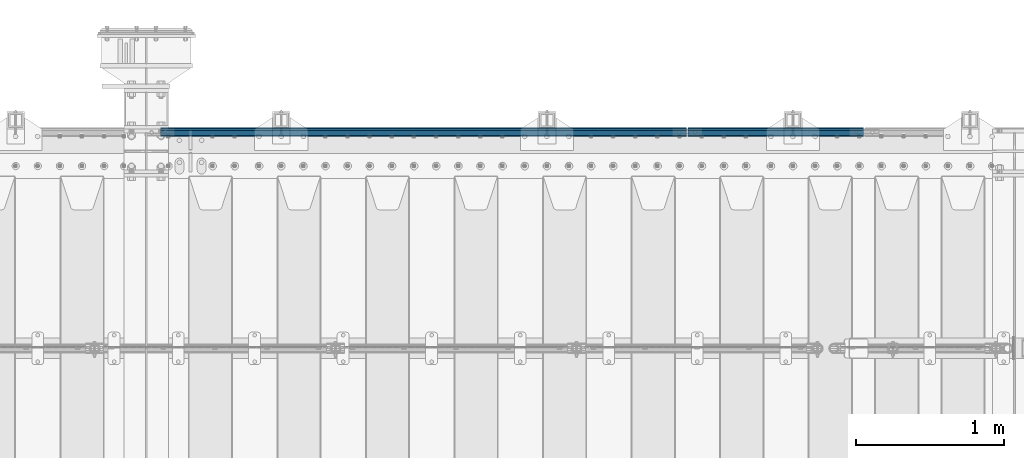
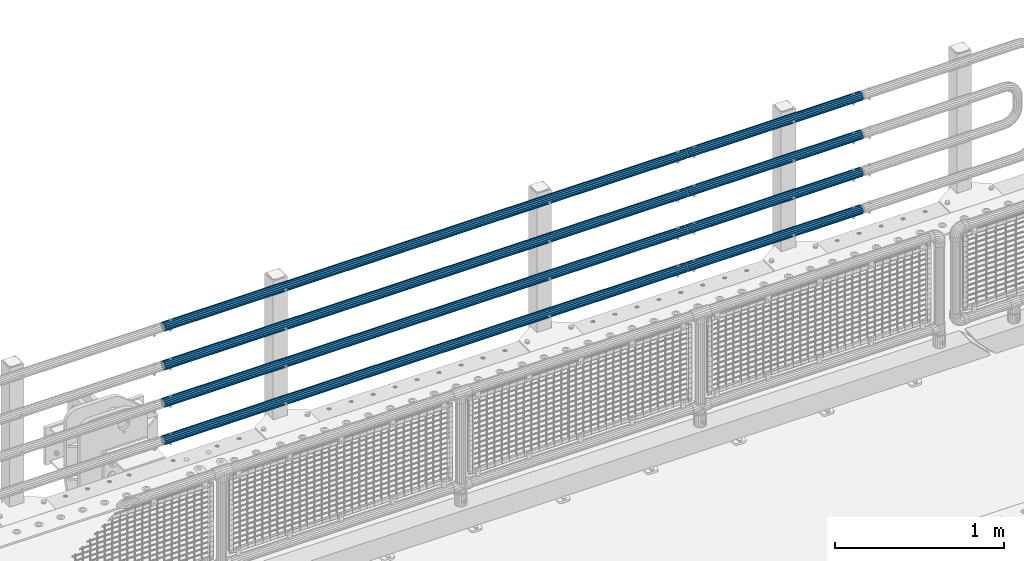
# One storey, part 135 of 242: 8 beams.
"""IFC2X3 building model written with IfcOpenShell, lengths in millimetres."""

import ifcopenshell
import ifcopenshell.guid

model = None  # the IFC model being written
_history = None  # IfcOwnerHistory: only IFC2X3 demands one
_inside = {}  # id of a spatial element -> (the spatial element, [elements in it])
_under = {}  # id of a project, library or spatial element -> (it, [spatial elements below it])
_declared = {}  # id of a project -> (the project, [libraries it declares])
_typed = {}  # id of a type object -> (the type object, [elements of that type])
_made_of = {}  # id of a material, layer set ... -> (it, [elements and type objects made of it])


def new_model(schema):
    """Start an empty IFC model of exactly this schema.

    Asked for "IFC4X3", IfcOpenShell would pick the latest addendum, in which some entities
    have other attributes; the version numbers below select the first issue.
    IFC2X3 requires an IfcOwnerHistory on every rooted entity: one is made here for all.
    """
    global model, _history
    if schema == "IFC4X3":
        model = ifcopenshell.file(schema_version=(4, 3, 0, 0))
    else:
        model = ifcopenshell.file(schema=schema)
    _inside.clear()
    _under.clear()
    _declared.clear()
    _typed.clear()
    _made_of.clear()
    _history = None
    if model.schema == "IFC2X3":
        org = make("IfcOrganization", Name="unknown")
        user = make(
            "IfcPersonAndOrganization",
            ThePerson=make("IfcPerson", FamilyName="unknown"),
            TheOrganization=org,
        )
        app = make(
            "IfcApplication",
            ApplicationDeveloper=org,
            Version="unknown",
            ApplicationFullName="unknown",
            ApplicationIdentifier="unknown",
        )
        _history = make(
            "IfcOwnerHistory",
            OwningUser=user,
            OwningApplication=app,
            ChangeAction="ADDED",
            CreationDate=0,
        )
    return model


def make(cls, **values):
    """One entity of the class cls with the attributes given. An attribute that is None is left unset."""
    return model.create_entity(
        cls, **{name: value for name, value in values.items() if value is not None}
    )


def rooted(cls, **values):
    """An entity with a GlobalId (a new one), such as an element, a storey or a relation."""
    return make(cls, GlobalId=ifcopenshell.guid.new(), OwnerHistory=_history, **values)


def si_unit(unit_type, name, prefix=None):
    """IfcSIUnit, for example si_unit("LENGTHUNIT", "METRE", prefix="MILLI")."""
    return make("IfcSIUnit", UnitType=unit_type, Prefix=prefix, Name=name)


def assignment(units):
    """IfcUnitAssignment: the units of a project."""
    return None if units is None else make("IfcUnitAssignment", Units=units)


def point(xyz):
    """IfcCartesianPoint."""
    return None if xyz is None else make("IfcCartesianPoint", Coordinates=xyz)


def direction(xyz):
    """IfcDirection."""
    return None if xyz is None else make("IfcDirection", DirectionRatios=xyz)


def frame(location, z_axis=None, x_axis=None):
    """IfcAxis2Placement3D, a coordinate frame: its origin and axes. An axis left out is left unset."""
    return make(
        "IfcAxis2Placement3D",
        Location=point(location),
        Axis=direction(z_axis),
        RefDirection=direction(x_axis),
    )


def origin_with_axes():
    """The frame at (0, 0, 0) with the z axis (0, 0, 1) and the x axis (1, 0, 0) written out."""
    return frame((0.0, 0.0, 0.0), z_axis=(0.0, 0.0, 1.0), x_axis=(1.0, 0.0, 0.0))


def place(relative_to, where):
    """IfcLocalPlacement: puts the frame where relative to a parent placement (None: the world)."""
    return make(
        "IfcLocalPlacement", PlacementRelTo=relative_to, RelativePlacement=where
    )


def context(
    kind, dimensions, precision=None, world=None, true_north=None, identifier=None
):
    """IfcGeometricRepresentationContext, for example the 3D "Model" context."""
    return make(
        "IfcGeometricRepresentationContext",
        ContextIdentifier=identifier,
        ContextType=kind,
        CoordinateSpaceDimension=dimensions,
        Precision=precision,
        WorldCoordinateSystem=world,
        TrueNorth=true_north,
    )


def subcontext(parent, identifier, kind, view, scale=None):
    """IfcGeometricRepresentationSubContext, for example "Body" below "Model"."""
    return make(
        "IfcGeometricRepresentationSubContext",
        ContextIdentifier=identifier,
        ContextType=kind,
        ParentContext=parent,
        TargetScale=scale,
        TargetView=view,
    )


def project(units=None, contexts=None):
    """IfcProject with its units and contexts."""
    return rooted(
        "IfcProject",
        Name="project",
        RepresentationContexts=contexts,
        UnitsInContext=assignment(units),
    )


def spatial(cls, under=None, at=None, **own):
    """A site, building, storey or space (cls), placed at a placement, below another one or the project."""
    s = rooted(cls, ObjectPlacement=at, **own)
    if under is not None:
        _under.setdefault(under.id(), (under, []))[1].append(s)
    return s


def faces_of(points, faces, orient=None, outer=None):
    """IfcFace entities. A face is a list of loops; a loop is a list of indices into points, from 0.

    orient and outer hold one flag for each loop. By default every Orientation is true, the
    first loop of a face is its IfcFaceOuterBound and the others are IfcFaceBound.
    """
    made = []
    for i, loops in enumerate(faces):
        bounds = []
        for j, loop in enumerate(loops):
            is_outer = j == 0 if outer is None else outer[i][j]
            bounds.append(
                make(
                    "IfcFaceOuterBound" if is_outer else "IfcFaceBound",
                    Bound=make("IfcPolyLoop", Polygon=[points[k] for k in loop]),
                    Orientation=True if orient is None else orient[i][j],
                )
            )
        made.append(make("IfcFace", Bounds=bounds))
    return made


def faceted_brep(points, faces, orient=None, outer=None, voids=None):
    """IfcFacetedBrep: a solid bounded by flat faces; with voids (closed shells), ...WithVoids."""
    shared = [point(p) for p in points]
    hull = make("IfcClosedShell", CfsFaces=faces_of(shared, faces, orient, outer))
    if voids is None:
        return make("IfcFacetedBrep", Outer=hull)
    return make(
        "IfcFacetedBrepWithVoids",
        Outer=hull,
        Voids=[
            make(cls, CfsFaces=faces_of(shared, fs, o, b)) for cls, fs, o, b in voids
        ],
    )


def shape(context_of_items, identifier, shape_type, items):
    """IfcShapeRepresentation: the items that make up one representation, for example the "Body"."""
    return make(
        "IfcShapeRepresentation",
        ContextOfItems=context_of_items,
        RepresentationIdentifier=identifier,
        RepresentationType=shape_type,
        Items=items,
    )


def material(Name=None, Category=None):
    """IfcMaterial."""
    return make("IfcMaterial", Name=Name, Category=Category)


def made_of(thing, what):
    """Note that an element or type object is made of a material, layer set ...; save() writes the relation."""
    if what is not None:
        _made_of.setdefault(what.id(), (what, []))[1].append(thing)
    return thing


def type_object(cls, material=None, **own):
    """A type object (cls), such as IfcWallType, which elements share."""
    return made_of(rooted(cls, **own), material)


def element(
    cls,
    number,
    at=None,
    inside=None,
    cuts=None,
    type_object=None,
    material=None,
    context=None,
    identifier="Body",
    shape_type=None,
    held_by="IfcProductDefinitionShape",
    body=None,
    shapes=None,
    **own,
):
    """One element of the class cls, such as IfcWall. Its Tag is "e" and its number.

    at: its placement. inside: the storey or other place that contains it. cuts: it is an
    opening in that element (IfcRelVoidsElement). A single representation is given by context,
    identifier, shape_type and body (its items); several are given by shapes. held_by: the class
    of the entity that holds the representations. save() writes the other relations.
    """
    e = rooted(cls, Tag="e%d" % number, ObjectPlacement=at, **own)
    if body is not None:
        shapes = [shape(context, identifier, shape_type, body)]
    if shapes is not None:
        e.Representation = make(held_by, Representations=shapes)
    if inside is not None:
        _inside.setdefault(inside.id(), (inside, []))[1].append(e)
    if cuts is not None:
        rooted(
            "IfcRelVoidsElement", RelatingBuildingElement=cuts, RelatedOpeningElement=e
        )
    if type_object is not None:
        _typed.setdefault(type_object.id(), (type_object, []))[1].append(e)
    return made_of(e, material)


def aggregate(whole, parts):
    """IfcRelAggregates: a whole, such as a stair, and the parts it consists of."""
    return rooted("IfcRelAggregates", RelatingObject=whole, RelatedObjects=parts)


def save(model, path):
    """Write the relations noted so far, then the file.

    IfcRelAggregates (storeys below a building ...), IfcRelContainedInSpatialStructure (elements
    in a storey), IfcRelDefinesByType, IfcRelAssociatesMaterial and IfcRelDeclares: one each for
    every whole, place, type object, material and project.
    """
    for whole, parts in _under.values():
        aggregate(whole, parts)
    for where, things in _inside.values():
        rooted(
            "IfcRelContainedInSpatialStructure",
            RelatedElements=things,
            RelatingStructure=where,
        )
    for kind, things in _typed.values():
        rooted("IfcRelDefinesByType", RelatedObjects=things, RelatingType=kind)
    for what, things in _made_of.values():
        rooted("IfcRelAssociatesMaterial", RelatedObjects=things, RelatingMaterial=what)
    for by, libraries in _declared.values():
        rooted("IfcRelDeclares", RelatingContext=by, RelatedDefinitions=libraries)
    model.write(path)


model = new_model("IFC2X3")

# Units and contexts
model_context = context("Model", 3, precision=1e-05, world=origin_with_axes())
body_context = subcontext(model_context, "Body", "Model", "MODEL_VIEW")
ifc_project = project(units=[si_unit("LENGTHUNIT", "METRE", prefix="MILLI"), si_unit("AREAUNIT", "SQUARE_METRE"), si_unit("VOLUMEUNIT", "CUBIC_METRE"), si_unit("MASSUNIT", "GRAM", prefix="KILO"), si_unit("TIMEUNIT", "SECOND"), si_unit("PLANEANGLEUNIT", "RADIAN"), si_unit("SOLIDANGLEUNIT", "STERADIAN"), si_unit("THERMODYNAMICTEMPERATUREUNIT", "DEGREE_CELSIUS"), si_unit("LUMINOUSINTENSITYUNIT", "LUMEN")], contexts=[model_context])

# Site, building, storey
site_placement = place(None, origin_with_axes())
site = spatial("IfcSite", under=ifc_project, at=site_placement, CompositionType="ELEMENT")
building_placement = place(site_placement, origin_with_axes())
building = spatial("IfcBuilding", under=site, at=building_placement, Name="Standard", CompositionType="ELEMENT")
storey_placement = place(building_placement, origin_with_axes())
storey = spatial("IfcBuildingStorey", under=building, at=storey_placement, Name="Undefined", CompositionType="ELEMENT", Elevation=0.0)

# Beams
ifc_material = material()
beam_type = type_object("IfcBeamType", PredefinedType="NOTDEFINED")
beam_1_placement = place(storey_placement, frame((-24755.0000000001, -17870.1499999998, 149.849999999726), z_axis=(0.0, 0.0, -1.0), x_axis=(-1.0, 0.0, 0.0)))
element("IfcBeam", 1, at=beam_1_placement, inside=storey, type_object=beam_type, material=ifc_material, context=body_context, shape_type="Brep", body=[
    faceted_brep([(0.0, -26.5499999999993, 0.0), (0.0, -24.5290015881765, 10.1602451292931), (3563.0, -24.5290015881765, 10.1602451292931), (3563.0, -26.5499999999993, 0.0), (0.0, -18.7736850405017, 18.7736850405028), (3563.0, -18.7736850405017, 18.7736850405028), (0.0, -10.1602451292929, 24.5290015881747), (3563.0, -10.1602451292929, 24.5290015881747), (0.0, 0.0, 26.55), (3563.0, 0.0, 26.55), (0.0, 10.1602451292929, 24.5290015881747), (3563.0, 10.1602451292929, 24.5290015881747), (0.0, 18.7736850405017, 18.7736850405028), (3563.0, 18.7736850405017, 18.7736850405028), (0.0, 24.5290015881765, 10.1602451292931), (3563.0, 24.5290015881765, 10.1602451292931), (0.0, 26.5499999999993, 0.0), (3563.0, 26.5499999999993, 0.0), (0.0, 24.5290015881765, -10.1602451292931), (3563.0, 24.5290015881765, -10.1602451292931), (0.0, 18.7736850405017, -18.7736850405028), (3563.0, 18.7736850405017, -18.7736850405028), (0.0, 10.1602451292929, -24.5290015881747), (3563.0, 10.1602451292929, -24.5290015881747), (0.0, 0.0, -26.55), (3563.0, 0.0, -26.55), (0.0, -10.1602451292929, -24.5290015881747), (3563.0, -10.1602451292929, -24.5290015881747), (0.0, -18.7736850405017, -18.7736850405028), (3563.0, -18.7736850405017, -18.7736850405028), (0.0, -24.5290015881765, -10.1602451292931), (3563.0, -24.5290015881765, -10.1602451292931), (0.0, -30.1500000000015, 0.0), (0.0, -27.8549679052157, -11.5379054858058), (3563.0, -27.8549679052157, -11.5379054858075), (3563.0, -30.1500000000015, 0.0), (0.0, -21.3192694527752, -21.3192694527752), (3563.0, -21.3192694527752, -21.3192694527744), (0.0, -11.5379054858058, -27.8549679052157), (3563.0, -11.5379054858058, -27.8549679052153), (0.0, 0.0, -30.1500000000015), (3563.0, 0.0, -30.15), (0.0, 11.5379054858058, -27.8549679052157), (3563.0, 11.5379054858058, -27.8549679052153), (0.0, 21.3192694527752, -21.3192694527752), (3563.0, 21.3192694527752, -21.3192694527744), (0.0, 27.8549679052157, -11.5379054858058), (3563.0, 27.8549679052157, -11.5379054858074), (0.0, 30.1500000000015, 0.0), (3563.0, 30.1500000000015, 0.0), (0.0, 27.8549679052157, 11.5379054858058), (3563.0, 27.8549679052157, 11.5379054858075), (0.0, 21.3192694527752, 21.3192694527752), (3563.0, 21.3192694527752, 21.3192694527744), (0.0, 11.5379054858058, 27.8549679052157), (3563.0, 11.5379054858058, 27.8549679052153), (0.0, 0.0, 30.1500000000015), (3563.0, 0.0, 30.15), (0.0, -11.5379054858058, 27.8549679052157), (3563.0, -11.5379054858058, 27.8549679052153), (0.0, -21.3192694527752, 21.3192694527752), (3563.0, -21.3192694527752, 21.3192694527744), (0.0, -27.8549679052157, 11.5379054858058), (3563.0, -27.8549679052157, 11.5379054858075)], [[[0, 1, 2, 3]], [[1, 4, 5, 2]], [[4, 6, 7, 5]], [[6, 8, 9, 7]], [[8, 10, 11, 9]], [[10, 12, 13, 11]], [[12, 14, 15, 13]], [[14, 16, 17, 15]], [[16, 18, 19, 17]], [[18, 20, 21, 19]], [[20, 22, 23, 21]], [[22, 24, 25, 23]], [[24, 26, 27, 25]], [[26, 28, 29, 27]], [[28, 30, 31, 29]], [[30, 0, 3, 31]], [[32, 33, 34, 35]], [[33, 36, 37, 34]], [[36, 38, 39, 37]], [[38, 40, 41, 39]], [[40, 42, 43, 41]], [[42, 44, 45, 43]], [[44, 46, 47, 45]], [[46, 48, 49, 47]], [[48, 50, 51, 49]], [[50, 52, 53, 51]], [[52, 54, 55, 53]], [[54, 56, 57, 55]], [[56, 58, 59, 57]], [[58, 60, 61, 59]], [[60, 62, 63, 61]], [[62, 32, 35, 63]], [[37, 39, 41, 43, 45, 47, 49, 51, 53, 55, 57, 59, 61, 63, 35, 34], [5, 7, 9, 11, 13, 15, 17, 19, 21, 23, 25, 27, 29, 31, 3, 2]], [[62, 60, 58, 56, 54, 52, 50, 48, 46, 44, 42, 40, 38, 36, 33, 32], [30, 28, 26, 24, 22, 20, 18, 16, 14, 12, 10, 8, 6, 4, 1, 0]]]),
])
beam_2_placement = place(storey_placement, frame((-24755.0000000001, -17870.1499999998, 420.149999999725), z_axis=(0.0, 0.0, -1.0), x_axis=(-1.0, 0.0, 0.0)))
element("IfcBeam", 2, at=beam_2_placement, inside=storey, type_object=beam_type, material=ifc_material, context=body_context, shape_type="Brep", body=[
    faceted_brep([(0.0, -26.5499999999993, 0.0), (0.0, -24.5290015881765, 10.1602451292931), (3563.0, -24.5290015881765, 10.1602451292931), (3563.0, -26.5499999999993, 0.0), (0.0, -18.7736850405017, 18.7736850405028), (3563.0, -18.7736850405017, 18.7736850405028), (0.0, -10.1602451292929, 24.5290015881747), (3563.0, -10.1602451292929, 24.5290015881747), (0.0, 0.0, 26.55), (3563.0, 0.0, 26.55), (0.0, 10.1602451292929, 24.5290015881747), (3563.0, 10.1602451292929, 24.5290015881747), (0.0, 18.7736850405017, 18.7736850405028), (3563.0, 18.7736850405017, 18.7736850405028), (0.0, 24.5290015881765, 10.1602451292931), (3563.0, 24.5290015881765, 10.1602451292931), (0.0, 26.5499999999993, 0.0), (3563.0, 26.5499999999993, 0.0), (0.0, 24.5290015881765, -10.1602451292931), (3563.0, 24.5290015881765, -10.1602451292931), (0.0, 18.7736850405017, -18.7736850405028), (3563.0, 18.7736850405017, -18.7736850405028), (0.0, 10.1602451292929, -24.5290015881747), (3563.0, 10.1602451292929, -24.5290015881747), (0.0, 0.0, -26.55), (3563.0, 0.0, -26.55), (0.0, -10.1602451292929, -24.5290015881747), (3563.0, -10.1602451292929, -24.5290015881747), (0.0, -18.7736850405017, -18.7736850405028), (3563.0, -18.7736850405017, -18.7736850405028), (0.0, -24.5290015881765, -10.1602451292931), (3563.0, -24.5290015881765, -10.1602451292931), (0.0, -30.1500000000015, 0.0), (0.0, -27.8549679052157, -11.5379054858058), (3563.0, -27.8549679052157, -11.5379054858075), (3563.0, -30.1500000000015, 0.0), (0.0, -21.3192694527752, -21.3192694527752), (3563.0, -21.3192694527752, -21.3192694527744), (0.0, -11.5379054858058, -27.8549679052157), (3563.0, -11.5379054858058, -27.8549679052153), (0.0, 0.0, -30.1500000000015), (3563.0, 0.0, -30.15), (0.0, 11.5379054858058, -27.8549679052157), (3563.0, 11.5379054858058, -27.8549679052153), (0.0, 21.3192694527752, -21.3192694527752), (3563.0, 21.3192694527752, -21.3192694527744), (0.0, 27.8549679052157, -11.5379054858058), (3563.0, 27.8549679052157, -11.5379054858074), (0.0, 30.1500000000015, 0.0), (3563.0, 30.1500000000015, 0.0), (0.0, 27.8549679052157, 11.5379054858058), (3563.0, 27.8549679052157, 11.5379054858075), (0.0, 21.3192694527752, 21.3192694527752), (3563.0, 21.3192694527752, 21.3192694527744), (0.0, 11.5379054858058, 27.8549679052157), (3563.0, 11.5379054858058, 27.8549679052153), (0.0, 0.0, 30.1500000000015), (3563.0, 0.0, 30.15), (0.0, -11.5379054858058, 27.8549679052157), (3563.0, -11.5379054858058, 27.8549679052153), (0.0, -21.3192694527752, 21.3192694527752), (3563.0, -21.3192694527752, 21.3192694527744), (0.0, -27.8549679052157, 11.5379054858058), (3563.0, -27.8549679052157, 11.5379054858075)], [[[0, 1, 2, 3]], [[1, 4, 5, 2]], [[4, 6, 7, 5]], [[6, 8, 9, 7]], [[8, 10, 11, 9]], [[10, 12, 13, 11]], [[12, 14, 15, 13]], [[14, 16, 17, 15]], [[16, 18, 19, 17]], [[18, 20, 21, 19]], [[20, 22, 23, 21]], [[22, 24, 25, 23]], [[24, 26, 27, 25]], [[26, 28, 29, 27]], [[28, 30, 31, 29]], [[30, 0, 3, 31]], [[32, 33, 34, 35]], [[33, 36, 37, 34]], [[36, 38, 39, 37]], [[38, 40, 41, 39]], [[40, 42, 43, 41]], [[42, 44, 45, 43]], [[44, 46, 47, 45]], [[46, 48, 49, 47]], [[48, 50, 51, 49]], [[50, 52, 53, 51]], [[52, 54, 55, 53]], [[54, 56, 57, 55]], [[56, 58, 59, 57]], [[58, 60, 61, 59]], [[60, 62, 63, 61]], [[62, 32, 35, 63]], [[37, 39, 41, 43, 45, 47, 49, 51, 53, 55, 57, 59, 61, 63, 35, 34], [5, 7, 9, 11, 13, 15, 17, 19, 21, 23, 25, 27, 29, 31, 3, 2]], [[62, 60, 58, 56, 54, 52, 50, 48, 46, 44, 42, 40, 38, 36, 33, 32], [30, 28, 26, 24, 22, 20, 18, 16, 14, 12, 10, 8, 6, 4, 1, 0]]]),
])
beam_3_placement = place(storey_placement, frame((-24755.0000000001, -17870.1499999998, 969.849999999726), z_axis=(0.0, 0.0, -1.0), x_axis=(-1.0, 0.0, 0.0)))
element("IfcBeam", 3, at=beam_3_placement, inside=storey, type_object=beam_type, material=ifc_material, context=body_context, shape_type="Brep", body=[
    faceted_brep([(0.0, -26.5499999999993, 0.0), (0.0, -24.5290015881765, 10.1602451292931), (3563.0, -24.5290015881765, 10.1602451292931), (3563.0, -26.5499999999993, 0.0), (0.0, -18.7736850405017, 18.7736850405028), (3563.0, -18.7736850405017, 18.7736850405028), (0.0, -10.1602451292929, 24.5290015881747), (3563.0, -10.1602451292929, 24.5290015881747), (0.0, 0.0, 26.55), (3563.0, 0.0, 26.55), (0.0, 10.1602451292929, 24.5290015881747), (3563.0, 10.1602451292929, 24.5290015881747), (0.0, 18.7736850405017, 18.7736850405028), (3563.0, 18.7736850405017, 18.7736850405028), (0.0, 24.5290015881765, 10.1602451292931), (3563.0, 24.5290015881765, 10.1602451292931), (0.0, 26.5499999999993, 0.0), (3563.0, 26.5499999999993, 0.0), (0.0, 24.5290015881765, -10.1602451292931), (3563.0, 24.5290015881765, -10.1602451292931), (0.0, 18.7736850405017, -18.7736850405028), (3563.0, 18.7736850405017, -18.7736850405028), (0.0, 10.1602451292929, -24.5290015881747), (3563.0, 10.1602451292929, -24.5290015881747), (0.0, 0.0, -26.55), (3563.0, 0.0, -26.55), (0.0, -10.1602451292929, -24.5290015881747), (3563.0, -10.1602451292929, -24.5290015881747), (0.0, -18.7736850405017, -18.7736850405028), (3563.0, -18.7736850405017, -18.7736850405028), (0.0, -24.5290015881765, -10.1602451292931), (3563.0, -24.5290015881765, -10.1602451292931), (0.0, -30.1500000000015, 0.0), (0.0, -27.8549679052157, -11.5379054858058), (3563.0, -27.8549679052157, -11.5379054858075), (3563.0, -30.1500000000015, 0.0), (0.0, -21.3192694527752, -21.3192694527752), (3563.0, -21.3192694527752, -21.3192694527744), (0.0, -11.5379054858058, -27.8549679052157), (3563.0, -11.5379054858058, -27.8549679052153), (0.0, 0.0, -30.1500000000015), (3563.0, 0.0, -30.15), (0.0, 11.5379054858058, -27.8549679052157), (3563.0, 11.5379054858058, -27.8549679052153), (0.0, 21.3192694527752, -21.3192694527752), (3563.0, 21.3192694527752, -21.3192694527744), (0.0, 27.8549679052157, -11.5379054858058), (3563.0, 27.8549679052157, -11.5379054858074), (0.0, 30.1500000000015, 0.0), (3563.0, 30.1500000000015, 0.0), (0.0, 27.8549679052157, 11.5379054858058), (3563.0, 27.8549679052157, 11.5379054858075), (0.0, 21.3192694527752, 21.3192694527752), (3563.0, 21.3192694527752, 21.3192694527744), (0.0, 11.5379054858058, 27.8549679052157), (3563.0, 11.5379054858058, 27.8549679052153), (0.0, 0.0, 30.1500000000015), (3563.0, 0.0, 30.15), (0.0, -11.5379054858058, 27.8549679052157), (3563.0, -11.5379054858058, 27.8549679052153), (0.0, -21.3192694527752, 21.3192694527752), (3563.0, -21.3192694527752, 21.3192694527744), (0.0, -27.8549679052157, 11.5379054858058), (3563.0, -27.8549679052157, 11.5379054858075)], [[[0, 1, 2, 3]], [[1, 4, 5, 2]], [[4, 6, 7, 5]], [[6, 8, 9, 7]], [[8, 10, 11, 9]], [[10, 12, 13, 11]], [[12, 14, 15, 13]], [[14, 16, 17, 15]], [[16, 18, 19, 17]], [[18, 20, 21, 19]], [[20, 22, 23, 21]], [[22, 24, 25, 23]], [[24, 26, 27, 25]], [[26, 28, 29, 27]], [[28, 30, 31, 29]], [[30, 0, 3, 31]], [[32, 33, 34, 35]], [[33, 36, 37, 34]], [[36, 38, 39, 37]], [[38, 40, 41, 39]], [[40, 42, 43, 41]], [[42, 44, 45, 43]], [[44, 46, 47, 45]], [[46, 48, 49, 47]], [[48, 50, 51, 49]], [[50, 52, 53, 51]], [[52, 54, 55, 53]], [[54, 56, 57, 55]], [[56, 58, 59, 57]], [[58, 60, 61, 59]], [[60, 62, 63, 61]], [[62, 32, 35, 63]], [[37, 39, 41, 43, 45, 47, 49, 51, 53, 55, 57, 59, 61, 63, 35, 34], [5, 7, 9, 11, 13, 15, 17, 19, 21, 23, 25, 27, 29, 31, 3, 2]], [[62, 60, 58, 56, 54, 52, 50, 48, 46, 44, 42, 40, 38, 36, 33, 32], [30, 28, 26, 24, 22, 20, 18, 16, 14, 12, 10, 8, 6, 4, 1, 0]]]),
])
beam_4_placement = place(storey_placement, frame((-24744.9999999999, -17870.1500000004, 419.849999999726), z_axis=(0.0, -1.0, 0.0), x_axis=(1.0, 0.0, 0.0)))
element("IfcBeam", 4, at=beam_4_placement, inside=storey, type_object=beam_type, material=ifc_material, context=body_context, shape_type="Brep", body=[
    faceted_brep([(0.0, -26.5499999999993, 0.0), (0.0, -24.5290015881765, 10.1602451292931), (1190.0, -24.5290015881747, 10.1602451292929), (1190.0, -26.55, 0.0), (0.0, -18.7736850405017, 18.7736850405028), (1190.0, -18.7736850405028, 18.7736850405017), (0.0, -10.1602451292929, 24.5290015881747), (1190.0, -10.1602451292931, 24.5290015881765), (0.0, 0.0, 26.55), (1190.0, 0.0, 26.5499999999993), (0.0, 10.1602451292929, 24.5290015881747), (1190.0, 10.1602451292932, 24.5290015881765), (0.0, 18.7736850405017, 18.7736850405028), (1190.0, 18.7736850405029, 18.7736850405017), (0.0, 24.5290015881765, 10.1602451292931), (1190.0, 24.5290015881747, 10.1602451292929), (0.0, 26.5499999999993, 0.0), (1190.0, 26.55, 0.0), (0.0, 24.5290015881765, -10.1602451292931), (1190.0, 24.5290015881747, -10.1602451292929), (0.0, 18.7736850405017, -18.7736850405028), (1190.0, 18.7736850405028, -18.7736850405017), (0.0, 10.1602451292929, -24.5290015881747), (1190.0, 10.1602451292931, -24.5290015881765), (0.0, 0.0, -26.55), (1190.0, 0.0, -26.5499999999993), (0.0, -10.1602451292929, -24.5290015881747), (1190.0, -10.1602451292931, -24.5290015881765), (0.0, -18.7736850405017, -18.7736850405028), (1190.0, -18.7736850405028, -18.7736850405017), (0.0, -24.5290015881765, -10.1602451292931), (1190.0, -24.5290015881747, -10.1602451292929), (0.0, -30.1500000000015, 0.0), (0.0, -27.8549679052157, -11.5379054858058), (1190.0, -27.8549679052153, -11.5379054858058), (1190.0, -30.15, 0.0), (0.0, -21.3192694527752, -21.3192694527752), (1190.0, -21.3192694527744, -21.3192694527752), (0.0, -11.5379054858058, -27.8549679052157), (1190.0, -11.5379054858075, -27.8549679052157), (0.0, 0.0, -30.1500000000015), (1190.0, 0.0, -30.1500000000015), (0.0, 11.5379054858058, -27.8549679052157), (1190.0, 11.5379054858075, -27.8549679052157), (0.0, 21.3192694527752, -21.3192694527752), (1190.0, 21.3192694527744, -21.3192694527752), (0.0, 27.8549679052157, -11.5379054858058), (1190.0, 27.8549679052153, -11.5379054858058), (0.0, 30.1500000000015, 0.0), (1190.0, 30.15, 0.0), (0.0, 27.8549679052157, 11.5379054858058), (1190.0, 27.8549679052153, 11.5379054858058), (0.0, 21.3192694527752, 21.3192694527752), (1190.0, 21.3192694527744, 21.3192694527752), (0.0, 11.5379054858058, 27.8549679052157), (1190.0, 11.5379054858075, 27.8549679052157), (0.0, 0.0, 30.1500000000015), (1190.0, 0.0, 30.1500000000015), (0.0, -11.5379054858058, 27.8549679052157), (1190.0, -11.5379054858075, 27.8549679052157), (0.0, -21.3192694527752, 21.3192694527752), (1190.0, -21.3192694527744, 21.3192694527752), (0.0, -27.8549679052157, 11.5379054858058), (1190.0, -27.8549679052153, 11.5379054858058)], [[[0, 1, 2, 3]], [[1, 4, 5, 2]], [[4, 6, 7, 5]], [[6, 8, 9, 7]], [[8, 10, 11, 9]], [[10, 12, 13, 11]], [[12, 14, 15, 13]], [[14, 16, 17, 15]], [[16, 18, 19, 17]], [[18, 20, 21, 19]], [[20, 22, 23, 21]], [[22, 24, 25, 23]], [[24, 26, 27, 25]], [[26, 28, 29, 27]], [[28, 30, 31, 29]], [[30, 0, 3, 31]], [[32, 33, 34, 35]], [[33, 36, 37, 34]], [[36, 38, 39, 37]], [[38, 40, 41, 39]], [[40, 42, 43, 41]], [[42, 44, 45, 43]], [[44, 46, 47, 45]], [[46, 48, 49, 47]], [[48, 50, 51, 49]], [[50, 52, 53, 51]], [[52, 54, 55, 53]], [[54, 56, 57, 55]], [[56, 58, 59, 57]], [[58, 60, 61, 59]], [[60, 62, 63, 61]], [[62, 32, 35, 63]], [[37, 39, 41, 43, 45, 47, 49, 51, 53, 55, 57, 59, 61, 63, 35, 34], [5, 7, 9, 11, 13, 15, 17, 19, 21, 23, 25, 27, 29, 31, 3, 2]], [[62, 60, 58, 56, 54, 52, 50, 48, 46, 44, 42, 40, 38, 36, 33, 32], [30, 28, 26, 24, 22, 20, 18, 16, 14, 12, 10, 8, 6, 4, 1, 0]]]),
])
beam_5_placement = place(storey_placement, frame((-24744.9999999999, -17870.1500000004, 149.549999999726), z_axis=(0.0, -1.0, 0.0), x_axis=(1.0, 0.0, 0.0)))
element("IfcBeam", 5, at=beam_5_placement, inside=storey, type_object=beam_type, material=ifc_material, context=body_context, shape_type="Brep", body=[
    faceted_brep([(0.0, -26.5499999999993, 0.0), (0.0, -24.5290015881765, 10.1602451292931), (1190.0, -24.5290015881747, 10.1602451292929), (1190.0, -26.55, 0.0), (0.0, -18.7736850405017, 18.7736850405028), (1190.0, -18.7736850405028, 18.7736850405017), (0.0, -10.1602451292929, 24.5290015881747), (1190.0, -10.1602451292931, 24.5290015881765), (0.0, 0.0, 26.55), (1190.0, 0.0, 26.5499999999993), (0.0, 10.1602451292929, 24.5290015881747), (1190.0, 10.1602451292932, 24.5290015881765), (0.0, 18.7736850405017, 18.7736850405028), (1190.0, 18.7736850405029, 18.7736850405017), (0.0, 24.5290015881765, 10.1602451292931), (1190.0, 24.5290015881747, 10.1602451292929), (0.0, 26.5499999999993, 0.0), (1190.0, 26.55, 0.0), (0.0, 24.5290015881765, -10.1602451292931), (1190.0, 24.5290015881747, -10.1602451292929), (0.0, 18.7736850405017, -18.7736850405028), (1190.0, 18.7736850405028, -18.7736850405017), (0.0, 10.1602451292929, -24.5290015881747), (1190.0, 10.1602451292931, -24.5290015881765), (0.0, 0.0, -26.55), (1190.0, 0.0, -26.5499999999993), (0.0, -10.1602451292929, -24.5290015881747), (1190.0, -10.1602451292931, -24.5290015881765), (0.0, -18.7736850405017, -18.7736850405028), (1190.0, -18.7736850405028, -18.7736850405017), (0.0, -24.5290015881765, -10.1602451292931), (1190.0, -24.5290015881747, -10.1602451292929), (0.0, -30.1500000000015, 0.0), (0.0, -27.8549679052157, -11.5379054858058), (1190.0, -27.8549679052153, -11.5379054858058), (1190.0, -30.15, 0.0), (0.0, -21.3192694527752, -21.3192694527752), (1190.0, -21.3192694527744, -21.3192694527752), (0.0, -11.5379054858058, -27.8549679052157), (1190.0, -11.5379054858075, -27.8549679052157), (0.0, 0.0, -30.1500000000015), (1190.0, 0.0, -30.1500000000015), (0.0, 11.5379054858058, -27.8549679052157), (1190.0, 11.5379054858075, -27.8549679052157), (0.0, 21.3192694527752, -21.3192694527752), (1190.0, 21.3192694527744, -21.3192694527752), (0.0, 27.8549679052157, -11.5379054858058), (1190.0, 27.8549679052153, -11.5379054858058), (0.0, 30.1500000000015, 0.0), (1190.0, 30.15, 0.0), (0.0, 27.8549679052157, 11.5379054858058), (1190.0, 27.8549679052153, 11.5379054858058), (0.0, 21.3192694527752, 21.3192694527752), (1190.0, 21.3192694527744, 21.3192694527752), (0.0, 11.5379054858058, 27.8549679052157), (1190.0, 11.5379054858075, 27.8549679052157), (0.0, 0.0, 30.1500000000015), (1190.0, 0.0, 30.1500000000015), (0.0, -11.5379054858058, 27.8549679052157), (1190.0, -11.5379054858075, 27.8549679052157), (0.0, -21.3192694527752, 21.3192694527752), (1190.0, -21.3192694527744, 21.3192694527752), (0.0, -27.8549679052157, 11.5379054858058), (1190.0, -27.8549679052153, 11.5379054858058)], [[[0, 1, 2, 3]], [[1, 4, 5, 2]], [[4, 6, 7, 5]], [[6, 8, 9, 7]], [[8, 10, 11, 9]], [[10, 12, 13, 11]], [[12, 14, 15, 13]], [[14, 16, 17, 15]], [[16, 18, 19, 17]], [[18, 20, 21, 19]], [[20, 22, 23, 21]], [[22, 24, 25, 23]], [[24, 26, 27, 25]], [[26, 28, 29, 27]], [[28, 30, 31, 29]], [[30, 0, 3, 31]], [[32, 33, 34, 35]], [[33, 36, 37, 34]], [[36, 38, 39, 37]], [[38, 40, 41, 39]], [[40, 42, 43, 41]], [[42, 44, 45, 43]], [[44, 46, 47, 45]], [[46, 48, 49, 47]], [[48, 50, 51, 49]], [[50, 52, 53, 51]], [[52, 54, 55, 53]], [[54, 56, 57, 55]], [[56, 58, 59, 57]], [[58, 60, 61, 59]], [[60, 62, 63, 61]], [[62, 32, 35, 63]], [[37, 39, 41, 43, 45, 47, 49, 51, 53, 55, 57, 59, 61, 63, 35, 34], [5, 7, 9, 11, 13, 15, 17, 19, 21, 23, 25, 27, 29, 31, 3, 2]], [[62, 60, 58, 56, 54, 52, 50, 48, 46, 44, 42, 40, 38, 36, 33, 32], [30, 28, 26, 24, 22, 20, 18, 16, 14, 12, 10, 8, 6, 4, 1, 0]]]),
])
beam_6_placement = place(storey_placement, frame((-24744.9999999999, -17870.1500000004, 969.549999999726), z_axis=(0.0, -1.0, 0.0), x_axis=(1.0, 0.0, 0.0)))
element("IfcBeam", 6, at=beam_6_placement, inside=storey, type_object=beam_type, material=ifc_material, context=body_context, shape_type="Brep", body=[
    faceted_brep([(0.0, -26.5499999999993, 0.0), (0.0, -24.5290015881765, 10.1602451292931), (1190.0, -24.5290015881747, 10.1602451292929), (1190.0, -26.55, 0.0), (0.0, -18.7736850405017, 18.7736850405028), (1190.0, -18.7736850405028, 18.7736850405017), (0.0, -10.1602451292929, 24.5290015881747), (1190.0, -10.1602451292931, 24.5290015881765), (0.0, 0.0, 26.55), (1190.0, 0.0, 26.5499999999993), (0.0, 10.1602451292929, 24.5290015881747), (1190.0, 10.1602451292932, 24.5290015881765), (0.0, 18.7736850405017, 18.7736850405028), (1190.0, 18.7736850405029, 18.7736850405017), (0.0, 24.5290015881765, 10.1602451292931), (1190.0, 24.5290015881747, 10.1602451292929), (0.0, 26.5499999999993, 0.0), (1190.0, 26.55, 0.0), (0.0, 24.5290015881765, -10.1602451292931), (1190.0, 24.5290015881747, -10.1602451292929), (0.0, 18.7736850405017, -18.7736850405028), (1190.0, 18.7736850405028, -18.7736850405017), (0.0, 10.1602451292929, -24.5290015881747), (1190.0, 10.1602451292931, -24.5290015881765), (0.0, 0.0, -26.55), (1190.0, 0.0, -26.5499999999993), (0.0, -10.1602451292929, -24.5290015881747), (1190.0, -10.1602451292931, -24.5290015881765), (0.0, -18.7736850405017, -18.7736850405028), (1190.0, -18.7736850405028, -18.7736850405017), (0.0, -24.5290015881765, -10.1602451292931), (1190.0, -24.5290015881747, -10.1602451292929), (0.0, -30.1500000000015, 0.0), (0.0, -27.8549679052157, -11.5379054858058), (1190.0, -27.8549679052153, -11.5379054858058), (1190.0, -30.15, 0.0), (0.0, -21.3192694527752, -21.3192694527752), (1190.0, -21.3192694527744, -21.3192694527752), (0.0, -11.5379054858058, -27.8549679052157), (1190.0, -11.5379054858075, -27.8549679052157), (0.0, 0.0, -30.1500000000015), (1190.0, 0.0, -30.1500000000015), (0.0, 11.5379054858058, -27.8549679052157), (1190.0, 11.5379054858075, -27.8549679052157), (0.0, 21.3192694527752, -21.3192694527752), (1190.0, 21.3192694527744, -21.3192694527752), (0.0, 27.8549679052157, -11.5379054858058), (1190.0, 27.8549679052153, -11.5379054858058), (0.0, 30.1500000000015, 0.0), (1190.0, 30.15, 0.0), (0.0, 27.8549679052157, 11.5379054858058), (1190.0, 27.8549679052153, 11.5379054858058), (0.0, 21.3192694527752, 21.3192694527752), (1190.0, 21.3192694527744, 21.3192694527752), (0.0, 11.5379054858058, 27.8549679052157), (1190.0, 11.5379054858075, 27.8549679052157), (0.0, 0.0, 30.1500000000015), (1190.0, 0.0, 30.1500000000015), (0.0, -11.5379054858058, 27.8549679052157), (1190.0, -11.5379054858075, 27.8549679052157), (0.0, -21.3192694527752, 21.3192694527752), (1190.0, -21.3192694527744, 21.3192694527752), (0.0, -27.8549679052157, 11.5379054858058), (1190.0, -27.8549679052153, 11.5379054858058)], [[[0, 1, 2, 3]], [[1, 4, 5, 2]], [[4, 6, 7, 5]], [[6, 8, 9, 7]], [[8, 10, 11, 9]], [[10, 12, 13, 11]], [[12, 14, 15, 13]], [[14, 16, 17, 15]], [[16, 18, 19, 17]], [[18, 20, 21, 19]], [[20, 22, 23, 21]], [[22, 24, 25, 23]], [[24, 26, 27, 25]], [[26, 28, 29, 27]], [[28, 30, 31, 29]], [[30, 0, 3, 31]], [[32, 33, 34, 35]], [[33, 36, 37, 34]], [[36, 38, 39, 37]], [[38, 40, 41, 39]], [[40, 42, 43, 41]], [[42, 44, 45, 43]], [[44, 46, 47, 45]], [[46, 48, 49, 47]], [[48, 50, 51, 49]], [[50, 52, 53, 51]], [[52, 54, 55, 53]], [[54, 56, 57, 55]], [[56, 58, 59, 57]], [[58, 60, 61, 59]], [[60, 62, 63, 61]], [[62, 32, 35, 63]], [[37, 39, 41, 43, 45, 47, 49, 51, 53, 55, 57, 59, 61, 63, 35, 34], [5, 7, 9, 11, 13, 15, 17, 19, 21, 23, 25, 27, 29, 31, 3, 2]], [[62, 60, 58, 56, 54, 52, 50, 48, 46, 44, 42, 40, 38, 36, 33, 32], [30, 28, 26, 24, 22, 20, 18, 16, 14, 12, 10, 8, 6, 4, 1, 0]]]),
])
beam_7_placement = place(storey_placement, frame((-24744.9999999999, -17870.1500000004, 689.549999999726), z_axis=(0.0, -1.0, 0.0), x_axis=(1.0, 0.0, 0.0)))
element("IfcBeam", 7, at=beam_7_placement, inside=storey, type_object=beam_type, material=ifc_material, context=body_context, shape_type="Brep", body=[
    faceted_brep([(0.0, -26.5499999999993, 0.0), (0.0, -24.5290015881765, 10.1602451292931), (1190.0, -24.5290015881747, 10.1602451292929), (1190.0, -26.55, 0.0), (0.0, -18.7736850405017, 18.7736850405028), (1190.0, -18.7736850405028, 18.7736850405017), (0.0, -10.1602451292929, 24.5290015881747), (1190.0, -10.1602451292931, 24.5290015881765), (0.0, 0.0, 26.55), (1190.0, 0.0, 26.5499999999993), (0.0, 10.1602451292929, 24.5290015881747), (1190.0, 10.1602451292932, 24.5290015881765), (0.0, 18.7736850405017, 18.7736850405028), (1190.0, 18.7736850405029, 18.7736850405017), (0.0, 24.5290015881765, 10.1602451292931), (1190.0, 24.5290015881747, 10.1602451292929), (0.0, 26.5499999999993, 0.0), (1190.0, 26.55, 0.0), (0.0, 24.5290015881765, -10.1602451292931), (1190.0, 24.5290015881747, -10.1602451292929), (0.0, 18.7736850405017, -18.7736850405028), (1190.0, 18.7736850405028, -18.7736850405017), (0.0, 10.1602451292929, -24.5290015881747), (1190.0, 10.1602451292931, -24.5290015881765), (0.0, 0.0, -26.55), (1190.0, 0.0, -26.5499999999993), (0.0, -10.1602451292929, -24.5290015881747), (1190.0, -10.1602451292931, -24.5290015881765), (0.0, -18.7736850405017, -18.7736850405028), (1190.0, -18.7736850405028, -18.7736850405017), (0.0, -24.5290015881765, -10.1602451292931), (1190.0, -24.5290015881747, -10.1602451292929), (0.0, -30.1500000000015, 0.0), (0.0, -27.8549679052157, -11.5379054858058), (1190.0, -27.8549679052153, -11.5379054858058), (1190.0, -30.15, 0.0), (0.0, -21.3192694527752, -21.3192694527752), (1190.0, -21.3192694527744, -21.3192694527752), (0.0, -11.5379054858058, -27.8549679052157), (1190.0, -11.5379054858075, -27.8549679052157), (0.0, 0.0, -30.1500000000015), (1190.0, 0.0, -30.1500000000015), (0.0, 11.5379054858058, -27.8549679052157), (1190.0, 11.5379054858075, -27.8549679052157), (0.0, 21.3192694527752, -21.3192694527752), (1190.0, 21.3192694527744, -21.3192694527752), (0.0, 27.8549679052157, -11.5379054858058), (1190.0, 27.8549679052153, -11.5379054858058), (0.0, 30.1500000000015, 0.0), (1190.0, 30.15, 0.0), (0.0, 27.8549679052157, 11.5379054858058), (1190.0, 27.8549679052153, 11.5379054858058), (0.0, 21.3192694527752, 21.3192694527752), (1190.0, 21.3192694527744, 21.3192694527752), (0.0, 11.5379054858058, 27.8549679052157), (1190.0, 11.5379054858075, 27.8549679052157), (0.0, 0.0, 30.1500000000015), (1190.0, 0.0, 30.1500000000015), (0.0, -11.5379054858058, 27.8549679052157), (1190.0, -11.5379054858075, 27.8549679052157), (0.0, -21.3192694527752, 21.3192694527752), (1190.0, -21.3192694527744, 21.3192694527752), (0.0, -27.8549679052157, 11.5379054858058), (1190.0, -27.8549679052153, 11.5379054858058)], [[[0, 1, 2, 3]], [[1, 4, 5, 2]], [[4, 6, 7, 5]], [[6, 8, 9, 7]], [[8, 10, 11, 9]], [[10, 12, 13, 11]], [[12, 14, 15, 13]], [[14, 16, 17, 15]], [[16, 18, 19, 17]], [[18, 20, 21, 19]], [[20, 22, 23, 21]], [[22, 24, 25, 23]], [[24, 26, 27, 25]], [[26, 28, 29, 27]], [[28, 30, 31, 29]], [[30, 0, 3, 31]], [[32, 33, 34, 35]], [[33, 36, 37, 34]], [[36, 38, 39, 37]], [[38, 40, 41, 39]], [[40, 42, 43, 41]], [[42, 44, 45, 43]], [[44, 46, 47, 45]], [[46, 48, 49, 47]], [[48, 50, 51, 49]], [[50, 52, 53, 51]], [[52, 54, 55, 53]], [[54, 56, 57, 55]], [[56, 58, 59, 57]], [[58, 60, 61, 59]], [[60, 62, 63, 61]], [[62, 32, 35, 63]], [[37, 39, 41, 43, 45, 47, 49, 51, 53, 55, 57, 59, 61, 63, 35, 34], [5, 7, 9, 11, 13, 15, 17, 19, 21, 23, 25, 27, 29, 31, 3, 2]], [[62, 60, 58, 56, 54, 52, 50, 48, 46, 44, 42, 40, 38, 36, 33, 32], [30, 28, 26, 24, 22, 20, 18, 16, 14, 12, 10, 8, 6, 4, 1, 0]]]),
])
beam_8_placement = place(storey_placement, frame((-24755.0000000001, -17870.1499999998, 689.849999999726), z_axis=(0.0, 0.0, -1.0), x_axis=(-1.0, 0.0, 0.0)))
element("IfcBeam", 8, at=beam_8_placement, inside=storey, type_object=beam_type, material=ifc_material, context=body_context, shape_type="Brep", body=[
    faceted_brep([(0.0, -26.5499999999993, 0.0), (0.0, -24.5290015881765, 10.1602451292931), (3563.0, -24.5290015881765, 10.1602451292931), (3563.0, -26.5499999999993, 0.0), (0.0, -18.7736850405017, 18.7736850405028), (3563.0, -18.7736850405017, 18.7736850405028), (0.0, -10.1602451292929, 24.5290015881747), (3563.0, -10.1602451292929, 24.5290015881747), (0.0, 0.0, 26.55), (3563.0, 0.0, 26.55), (0.0, 10.1602451292929, 24.5290015881747), (3563.0, 10.1602451292929, 24.5290015881747), (0.0, 18.7736850405017, 18.7736850405028), (3563.0, 18.7736850405017, 18.7736850405028), (0.0, 24.5290015881765, 10.1602451292931), (3563.0, 24.5290015881765, 10.1602451292931), (0.0, 26.5499999999993, 0.0), (3563.0, 26.5499999999993, 0.0), (0.0, 24.5290015881765, -10.1602451292931), (3563.0, 24.5290015881765, -10.1602451292931), (0.0, 18.7736850405017, -18.7736850405028), (3563.0, 18.7736850405017, -18.7736850405028), (0.0, 10.1602451292929, -24.5290015881747), (3563.0, 10.1602451292929, -24.5290015881747), (0.0, 0.0, -26.55), (3563.0, 0.0, -26.55), (0.0, -10.1602451292929, -24.5290015881747), (3563.0, -10.1602451292929, -24.5290015881747), (0.0, -18.7736850405017, -18.7736850405028), (3563.0, -18.7736850405017, -18.7736850405028), (0.0, -24.5290015881765, -10.1602451292931), (3563.0, -24.5290015881765, -10.1602451292931), (0.0, -30.1500000000015, 0.0), (0.0, -27.8549679052157, -11.5379054858058), (3563.0, -27.8549679052157, -11.5379054858075), (3563.0, -30.1500000000015, 0.0), (0.0, -21.3192694527752, -21.3192694527752), (3563.0, -21.3192694527752, -21.3192694527744), (0.0, -11.5379054858058, -27.8549679052157), (3563.0, -11.5379054858058, -27.8549679052153), (0.0, 0.0, -30.1500000000015), (3563.0, 0.0, -30.15), (0.0, 11.5379054858058, -27.8549679052157), (3563.0, 11.5379054858058, -27.8549679052153), (0.0, 21.3192694527752, -21.3192694527752), (3563.0, 21.3192694527752, -21.3192694527744), (0.0, 27.8549679052157, -11.5379054858058), (3563.0, 27.8549679052157, -11.5379054858074), (0.0, 30.1500000000015, 0.0), (3563.0, 30.1500000000015, 0.0), (0.0, 27.8549679052157, 11.5379054858058), (3563.0, 27.8549679052157, 11.5379054858075), (0.0, 21.3192694527752, 21.3192694527752), (3563.0, 21.3192694527752, 21.3192694527744), (0.0, 11.5379054858058, 27.8549679052157), (3563.0, 11.5379054858058, 27.8549679052153), (0.0, 0.0, 30.1500000000015), (3563.0, 0.0, 30.15), (0.0, -11.5379054858058, 27.8549679052157), (3563.0, -11.5379054858058, 27.8549679052153), (0.0, -21.3192694527752, 21.3192694527752), (3563.0, -21.3192694527752, 21.3192694527744), (0.0, -27.8549679052157, 11.5379054858058), (3563.0, -27.8549679052157, 11.5379054858075)], [[[0, 1, 2, 3]], [[1, 4, 5, 2]], [[4, 6, 7, 5]], [[6, 8, 9, 7]], [[8, 10, 11, 9]], [[10, 12, 13, 11]], [[12, 14, 15, 13]], [[14, 16, 17, 15]], [[16, 18, 19, 17]], [[18, 20, 21, 19]], [[20, 22, 23, 21]], [[22, 24, 25, 23]], [[24, 26, 27, 25]], [[26, 28, 29, 27]], [[28, 30, 31, 29]], [[30, 0, 3, 31]], [[32, 33, 34, 35]], [[33, 36, 37, 34]], [[36, 38, 39, 37]], [[38, 40, 41, 39]], [[40, 42, 43, 41]], [[42, 44, 45, 43]], [[44, 46, 47, 45]], [[46, 48, 49, 47]], [[48, 50, 51, 49]], [[50, 52, 53, 51]], [[52, 54, 55, 53]], [[54, 56, 57, 55]], [[56, 58, 59, 57]], [[58, 60, 61, 59]], [[60, 62, 63, 61]], [[62, 32, 35, 63]], [[37, 39, 41, 43, 45, 47, 49, 51, 53, 55, 57, 59, 61, 63, 35, 34], [5, 7, 9, 11, 13, 15, 17, 19, 21, 23, 25, 27, 29, 31, 3, 2]], [[62, 60, 58, 56, 54, 52, 50, 48, 46, 44, 42, 40, 38, 36, 33, 32], [30, 28, 26, 24, 22, 20, 18, 16, 14, 12, 10, 8, 6, 4, 1, 0]]]),
])

save(model, "model.ifc")
